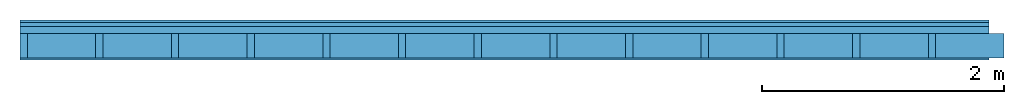
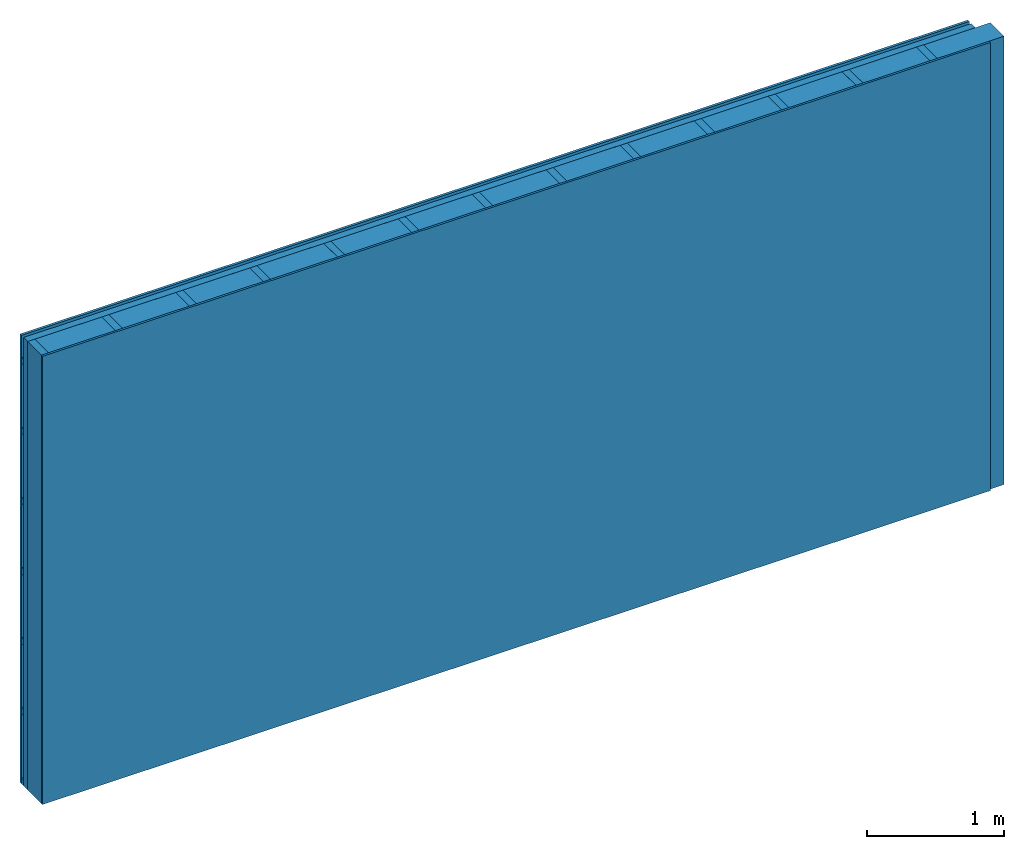
# One storey: 3 members, 3 plates, 1 element without a shape of its own.
"""IFC4 building model written with IfcOpenShell, lengths in metres."""

from ifc_helpers import new_model, si_unit, derived_unit, direction, frame, frame_2d, origin, origin_with_axes, place, context, project, spatial, rectangle, extrude, material, layer, layer_set, type_object, element, aggregate, save


model = new_model("IFC4")

# Units and contexts
plan_context = context("Plan", 3, precision=1e-05, world=origin(), true_north=direction((0.0, 1.0)))
model_context = context("Model", 3, precision=1e-05, world=origin(), true_north=direction((0.0, 1.0)))
ifc_project = project(units=[si_unit("LENGTHUNIT", "METRE"), derived_unit("SOUNDPRESSUREUNIT", [(si_unit("PRESSUREUNIT", "PASCAL", prefix="MICRO"), 0)]), si_unit("ENERGYUNIT", "JOULE", prefix="MEGA"), si_unit("MASSUNIT", "GRAM", prefix="KILO"), derived_unit("THERMALTRANSMITTANCEUNIT", [(si_unit("POWERUNIT", "WATT"), 1), (si_unit("AREAUNIT", "SQUARE_METRE"), -1), (si_unit("THERMODYNAMICTEMPERATUREUNIT", "KELVIN"), -1)]), derived_unit("AREADENSITYUNIT", [(si_unit("MASSUNIT", "GRAM", prefix="KILO"), 1), (si_unit("AREAUNIT", "SQUARE_METRE"), -1)]), derived_unit("USERDEFINED", [(si_unit("ENERGYUNIT", "JOULE", prefix="MEGA"), 1), (si_unit("AREAUNIT", "SQUARE_METRE"), -1)])], contexts=[plan_context, model_context])

# Site, building, storey
site = spatial("IfcSite", under=ifc_project)
building_placement = place(None, origin())
building = spatial("IfcBuilding", under=site, at=building_placement)
storey_placement = place(building_placement, origin())
storey = spatial("IfcBuildingStorey", under=building, at=storey_placement)

# Wall, members, plates
ifc_material_1 = material(Name="Wood cladding horizontal, closed")
ifc_layer_1 = layer(ifc_material_1, 0.022, Name="Cover 1st layer")
ifc_layer_2 = layer(None, 0.03, Name="Battens / profiles (ventilation)")
ifc_material_2 = material(Category="10.009")
ifc_layer_3 = layer(ifc_material_2, 0.06, Name="outside 2nd layer")
ifc_material_3 = material(Name="of the art")
ifc_layer_4 = layer(ifc_material_3, 0.0, Name="Bond")
ifc_layer_5 = layer(None, 0.2, Name="Support")
ifc_layer_6 = layer(ifc_material_3, 0.0, Name="Bond")
ifc_material_4 = material(Category="07.013")
ifc_layer_7 = layer(ifc_material_4, 0.018, Name="1st layer")
ifc_layer_set = layer_set([ifc_layer_1, ifc_layer_2, ifc_layer_3, ifc_layer_4, ifc_layer_5, ifc_layer_6, ifc_layer_7])
wall_type = type_object("IfcWallType", Name="D0092", PredefinedType="NOTDEFINED", material=ifc_layer_set)
wall_placement = place(None, frame((0.0, 0.0, 0.0), z_axis=(0.0, -1.0, 0.0), x_axis=(1.0, 0.0, 0.0)))
wall = element("IfcWall", 1, at=wall_placement, inside=storey, type_object=wall_type, material=ifc_layer_set, Name="Wall #1")
ifc_material_5 = material()
member_1_placement = place(wall_placement, origin())
member_1 = element("IfcMember", 2, at=member_1_placement, material=ifc_material_5, Name="Battens / profiles (ventilation)", context=plan_context, shape_type="SweptSolid", body=[
    extrude(rectangle(XDim=0.05, YDim=0.03, at=frame_2d((0.025, 0.015), x_axis=(1.0, 0.0))), frame((0.0, 0.0, 0.022), z_axis=(1.0, 0.0, 0.0), x_axis=(0.0, 1.0, 0.0)), (0.0, 0.0, 1.0), 8.0),
    extrude(rectangle(XDim=0.05, YDim=0.03, at=frame_2d((0.025, 0.015), x_axis=(1.0, 0.0))), frame((0.0, 0.625, 0.022), z_axis=(1.0, 0.0, 0.0), x_axis=(0.0, 1.0, 0.0)), (0.0, 0.0, 1.0), 8.0),
    extrude(rectangle(XDim=0.05, YDim=0.03, at=frame_2d((0.025, 0.015), x_axis=(1.0, 0.0))), frame((0.0, 1.25, 0.022), z_axis=(1.0, 0.0, 0.0), x_axis=(0.0, 1.0, 0.0)), (0.0, 0.0, 1.0), 8.0),
    extrude(rectangle(XDim=0.05, YDim=0.03, at=frame_2d((0.025, 0.015), x_axis=(1.0, 0.0))), frame((0.0, 1.875, 0.022), z_axis=(1.0, 0.0, 0.0), x_axis=(0.0, 1.0, 0.0)), (0.0, 0.0, 1.0), 8.0),
    extrude(rectangle(XDim=0.05, YDim=0.03, at=frame_2d((0.025, 0.015), x_axis=(1.0, 0.0))), frame((0.0, 2.5, 0.022), z_axis=(1.0, 0.0, 0.0), x_axis=(0.0, 1.0, 0.0)), (0.0, 0.0, 1.0), 8.0),
    extrude(rectangle(XDim=0.05, YDim=0.03, at=frame_2d((0.025, 0.015), x_axis=(1.0, 0.0))), frame((0.0, 3.125, 0.022), z_axis=(1.0, 0.0, 0.0), x_axis=(0.0, 1.0, 0.0)), (0.0, 0.0, 1.0), 8.0),
    extrude(rectangle(XDim=0.05, YDim=0.03, at=frame_2d((0.025, 0.015), x_axis=(1.0, 0.0))), frame((0.0, 3.75, 0.022), z_axis=(1.0, 0.0, 0.0), x_axis=(0.0, 1.0, 0.0)), (0.0, 0.0, 1.0), 8.0),
])
ifc_material_6 = material()
member_2_placement = place(wall_placement, origin())
member_2 = element("IfcMember", 3, at=member_2_placement, material=ifc_material_6, Name="Support", context=plan_context, shape_type="SweptSolid", body=[
    extrude(rectangle(XDim=0.06, YDim=0.2, at=frame_2d((0.03, 0.1), x_axis=(1.0, 0.0))), frame((0.0, 4.0, 0.112), z_axis=(0.0, -1.0, 0.0), x_axis=(1.0, 0.0, 0.0)), (0.0, 0.0, 1.0), 4.0),
    extrude(rectangle(XDim=0.06, YDim=0.2, at=frame_2d((0.03, 0.1), x_axis=(1.0, 0.0))), frame((0.625, 4.0, 0.112), z_axis=(0.0, -1.0, 0.0), x_axis=(1.0, 0.0, 0.0)), (0.0, 0.0, 1.0), 4.0),
    extrude(rectangle(XDim=0.06, YDim=0.2, at=frame_2d((0.03, 0.1), x_axis=(1.0, 0.0))), frame((1.25, 4.0, 0.112), z_axis=(0.0, -1.0, 0.0), x_axis=(1.0, 0.0, 0.0)), (0.0, 0.0, 1.0), 4.0),
    extrude(rectangle(XDim=0.06, YDim=0.2, at=frame_2d((0.03, 0.1), x_axis=(1.0, 0.0))), frame((1.875, 4.0, 0.112), z_axis=(0.0, -1.0, 0.0), x_axis=(1.0, 0.0, 0.0)), (0.0, 0.0, 1.0), 4.0),
    extrude(rectangle(XDim=0.06, YDim=0.2, at=frame_2d((0.03, 0.1), x_axis=(1.0, 0.0))), frame((2.5, 4.0, 0.112), z_axis=(0.0, -1.0, 0.0), x_axis=(1.0, 0.0, 0.0)), (0.0, 0.0, 1.0), 4.0),
    extrude(rectangle(XDim=0.06, YDim=0.2, at=frame_2d((0.03, 0.1), x_axis=(1.0, 0.0))), frame((3.125, 4.0, 0.112), z_axis=(0.0, -1.0, 0.0), x_axis=(1.0, 0.0, 0.0)), (0.0, 0.0, 1.0), 4.0),
    extrude(rectangle(XDim=0.06, YDim=0.2, at=frame_2d((0.03, 0.1), x_axis=(1.0, 0.0))), frame((3.75, 4.0, 0.112), z_axis=(0.0, -1.0, 0.0), x_axis=(1.0, 0.0, 0.0)), (0.0, 0.0, 1.0), 4.0),
    extrude(rectangle(XDim=0.06, YDim=0.2, at=frame_2d((0.03, 0.1), x_axis=(1.0, 0.0))), frame((4.375, 4.0, 0.112), z_axis=(0.0, -1.0, 0.0), x_axis=(1.0, 0.0, 0.0)), (0.0, 0.0, 1.0), 4.0),
    extrude(rectangle(XDim=0.06, YDim=0.2, at=frame_2d((0.03, 0.1), x_axis=(1.0, 0.0))), frame((5.0, 4.0, 0.112), z_axis=(0.0, -1.0, 0.0), x_axis=(1.0, 0.0, 0.0)), (0.0, 0.0, 1.0), 4.0),
    extrude(rectangle(XDim=0.06, YDim=0.2, at=frame_2d((0.03, 0.1), x_axis=(1.0, 0.0))), frame((5.625, 4.0, 0.112), z_axis=(0.0, -1.0, 0.0), x_axis=(1.0, 0.0, 0.0)), (0.0, 0.0, 1.0), 4.0),
    extrude(rectangle(XDim=0.06, YDim=0.2, at=frame_2d((0.03, 0.1), x_axis=(1.0, 0.0))), frame((6.25, 4.0, 0.112), z_axis=(0.0, -1.0, 0.0), x_axis=(1.0, 0.0, 0.0)), (0.0, 0.0, 1.0), 4.0),
    extrude(rectangle(XDim=0.06, YDim=0.2, at=frame_2d((0.03, 0.1), x_axis=(1.0, 0.0))), frame((6.875, 4.0, 0.112), z_axis=(0.0, -1.0, 0.0), x_axis=(1.0, 0.0, 0.0)), (0.0, 0.0, 1.0), 4.0),
    extrude(rectangle(XDim=0.06, YDim=0.2, at=frame_2d((0.03, 0.1), x_axis=(1.0, 0.0))), frame((7.5, 4.0, 0.112), z_axis=(0.0, -1.0, 0.0), x_axis=(1.0, 0.0, 0.0)), (0.0, 0.0, 1.0), 4.0),
])
ifc_material_7 = material()
member_3_placement = place(wall_placement, origin())
member_3 = element("IfcMember", 4, at=member_3_placement, material=ifc_material_7, Name="Cavity", context=plan_context, shape_type="SweptSolid", body=[
    extrude(rectangle(XDim=0.565, YDim=0.2, at=frame_2d((0.2825, 0.1), x_axis=(1.0, 0.0))), frame((0.06, 4.0, 0.112), z_axis=(0.0, -1.0, 0.0), x_axis=(1.0, 0.0, 0.0)), (0.0, 0.0, 1.0), 4.0),
    extrude(rectangle(XDim=0.565, YDim=0.2, at=frame_2d((0.2825, 0.1), x_axis=(1.0, 0.0))), frame((0.685, 4.0, 0.112), z_axis=(0.0, -1.0, 0.0), x_axis=(1.0, 0.0, 0.0)), (0.0, 0.0, 1.0), 4.0),
    extrude(rectangle(XDim=0.565, YDim=0.2, at=frame_2d((0.2825, 0.1), x_axis=(1.0, 0.0))), frame((1.31, 4.0, 0.112), z_axis=(0.0, -1.0, 0.0), x_axis=(1.0, 0.0, 0.0)), (0.0, 0.0, 1.0), 4.0),
    extrude(rectangle(XDim=0.565, YDim=0.2, at=frame_2d((0.2825, 0.1), x_axis=(1.0, 0.0))), frame((1.935, 4.0, 0.112), z_axis=(0.0, -1.0, 0.0), x_axis=(1.0, 0.0, 0.0)), (0.0, 0.0, 1.0), 4.0),
    extrude(rectangle(XDim=0.565, YDim=0.2, at=frame_2d((0.2825, 0.1), x_axis=(1.0, 0.0))), frame((2.56, 4.0, 0.112), z_axis=(0.0, -1.0, 0.0), x_axis=(1.0, 0.0, 0.0)), (0.0, 0.0, 1.0), 4.0),
    extrude(rectangle(XDim=0.565, YDim=0.2, at=frame_2d((0.2825, 0.1), x_axis=(1.0, 0.0))), frame((3.185, 4.0, 0.112), z_axis=(0.0, -1.0, 0.0), x_axis=(1.0, 0.0, 0.0)), (0.0, 0.0, 1.0), 4.0),
    extrude(rectangle(XDim=0.565, YDim=0.2, at=frame_2d((0.2825, 0.1), x_axis=(1.0, 0.0))), frame((3.81, 4.0, 0.112), z_axis=(0.0, -1.0, 0.0), x_axis=(1.0, 0.0, 0.0)), (0.0, 0.0, 1.0), 4.0),
    extrude(rectangle(XDim=0.565, YDim=0.2, at=frame_2d((0.2825, 0.1), x_axis=(1.0, 0.0))), frame((4.435, 4.0, 0.112), z_axis=(0.0, -1.0, 0.0), x_axis=(1.0, 0.0, 0.0)), (0.0, 0.0, 1.0), 4.0),
    extrude(rectangle(XDim=0.565, YDim=0.2, at=frame_2d((0.2825, 0.1), x_axis=(1.0, 0.0))), frame((5.06, 4.0, 0.112), z_axis=(0.0, -1.0, 0.0), x_axis=(1.0, 0.0, 0.0)), (0.0, 0.0, 1.0), 4.0),
    extrude(rectangle(XDim=0.565, YDim=0.2, at=frame_2d((0.2825, 0.1), x_axis=(1.0, 0.0))), frame((5.685, 4.0, 0.112), z_axis=(0.0, -1.0, 0.0), x_axis=(1.0, 0.0, 0.0)), (0.0, 0.0, 1.0), 4.0),
    extrude(rectangle(XDim=0.565, YDim=0.2, at=frame_2d((0.2825, 0.1), x_axis=(1.0, 0.0))), frame((6.31, 4.0, 0.112), z_axis=(0.0, -1.0, 0.0), x_axis=(1.0, 0.0, 0.0)), (0.0, 0.0, 1.0), 4.0),
    extrude(rectangle(XDim=0.565, YDim=0.2, at=frame_2d((0.2825, 0.1), x_axis=(1.0, 0.0))), frame((6.935, 4.0, 0.112), z_axis=(0.0, -1.0, 0.0), x_axis=(1.0, 0.0, 0.0)), (0.0, 0.0, 1.0), 4.0),
    extrude(rectangle(XDim=0.565, YDim=0.2, at=frame_2d((0.2825, 0.1), x_axis=(1.0, 0.0))), frame((7.56, 4.0, 0.112), z_axis=(0.0, -1.0, 0.0), x_axis=(1.0, 0.0, 0.0)), (0.0, 0.0, 1.0), 4.0),
])
plate_1_placement = place(wall_placement, origin())
plate_1 = element("IfcPlate", 5, at=plate_1_placement, material=ifc_material_1, Name="Cover 1st layer", context=plan_context, shape_type="SweptSolid", body=[
    extrude(rectangle(XDim=8.0, YDim=4.0, at=frame_2d((4.0, 2.0), x_axis=(1.0, 0.0))), origin_with_axes(), (0.0, 0.0, 1.0), 0.022),
])
plate_2_placement = place(wall_placement, origin())
plate_2 = element("IfcPlate", 6, at=plate_2_placement, material=ifc_material_2, Name="outside 2nd layer", context=plan_context, shape_type="SweptSolid", body=[
    extrude(rectangle(XDim=8.0, YDim=4.0, at=frame_2d((4.0, 2.0), x_axis=(1.0, 0.0))), frame((0.0, 0.0, 0.052), z_axis=(0.0, 0.0, 1.0), x_axis=(1.0, 0.0, 0.0)), (0.0, 0.0, 1.0), 0.06),
])
plate_3_placement = place(wall_placement, origin())
plate_3 = element("IfcPlate", 7, at=plate_3_placement, material=ifc_material_4, Name="1st layer", context=plan_context, shape_type="SweptSolid", body=[
    extrude(rectangle(XDim=8.0, YDim=4.0, at=frame_2d((4.0, 2.0), x_axis=(1.0, 0.0))), frame((0.0, 0.0, 0.312), z_axis=(0.0, 0.0, 1.0), x_axis=(1.0, 0.0, 0.0)), (0.0, 0.0, 1.0), 0.018),
])
aggregate(wall, [plate_1, member_1, plate_2, member_2, member_3, plate_3])

save(model, "model.ifc")
